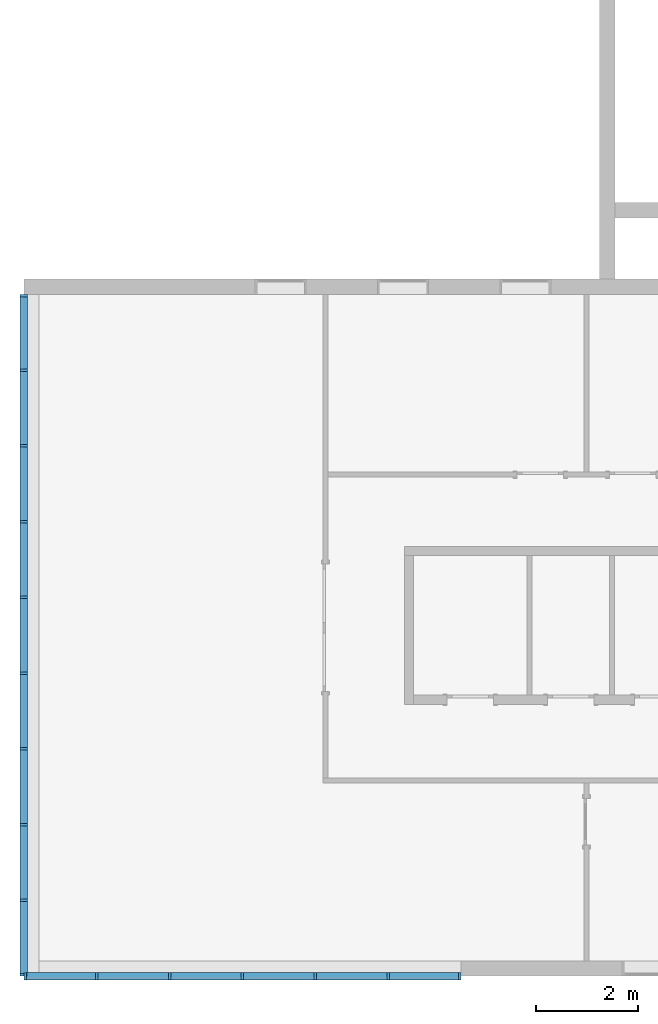
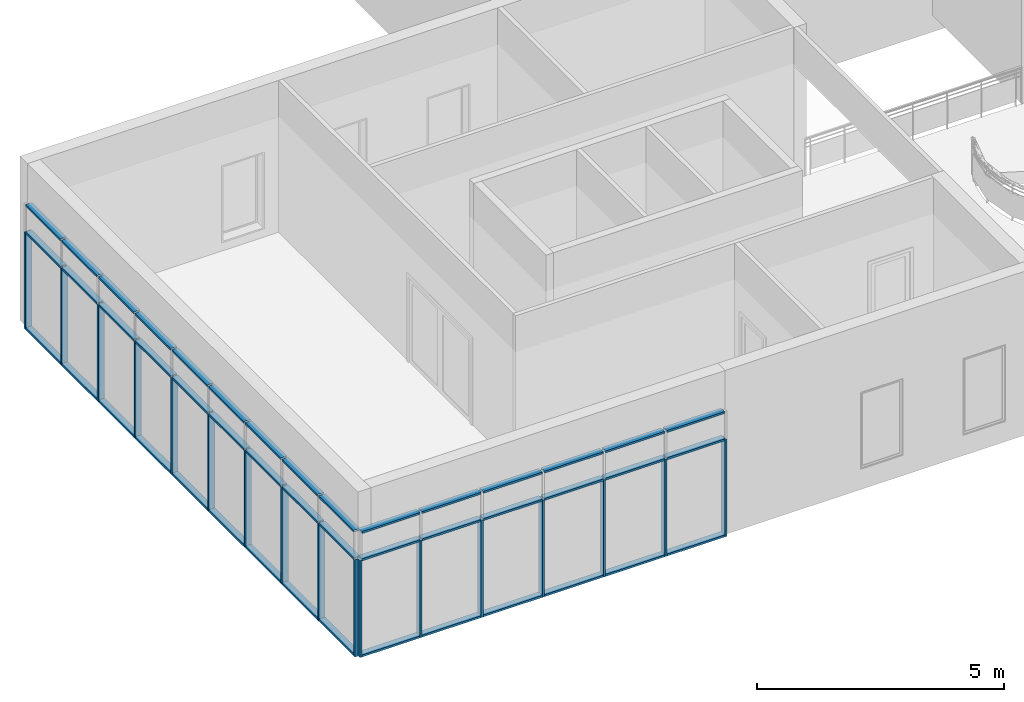
# One storey, part 1 of 13: 62 members, 2 elements without a shape of their own.
"""IFC2X3 building model written with IfcOpenShell, lengths in millimetres."""

from ifc_helpers import new_model, entity, si_unit, converted_unit, derived_unit, direction, frame, frame_2d, origin, origin_2d_with_axis, place, context, subcontext, project, spatial, rectangle, extrude, material, type_object, element, aggregate, save


model = new_model("IFC2X3")

# Units and contexts
model_context = context("Model", 3, precision=0.01, world=origin(), true_north=direction((6.12303176911189e-17, 1.0)))
context_of_model = context(None, 3, precision=0.01, world=origin(), true_north=direction((6.12303176911189e-17, 1.0)))
body_context = subcontext(model_context, "Body", "Model", "MODEL_VIEW")
ifc_project = project(units=[si_unit("LENGTHUNIT", "METRE", prefix="MILLI"), si_unit("AREAUNIT", "SQUARE_METRE"), si_unit("VOLUMEUNIT", "CUBIC_METRE"), converted_unit("PLANEANGLEUNIT", "DEGREE", entity("IfcRatioMeasure", 0.0174532925199433), si_unit("PLANEANGLEUNIT", "RADIAN"), dimensions=[0, 0, 0, 0, 0, 0, 0]), si_unit("MASSUNIT", "GRAM", prefix="KILO"), si_unit("TIMEUNIT", "SECOND"), si_unit("FREQUENCYUNIT", "HERTZ"), si_unit("THERMODYNAMICTEMPERATUREUNIT", "DEGREE_CELSIUS"), derived_unit("THERMALTRANSMITTANCEUNIT", [(si_unit("MASSUNIT", "GRAM", prefix="KILO"), 1), (si_unit("THERMODYNAMICTEMPERATUREUNIT", "KELVIN"), -1), (si_unit("TIMEUNIT", "SECOND"), -3)]), derived_unit("VOLUMETRICFLOWRATEUNIT", [(si_unit("LENGTHUNIT", "METRE"), 3), (si_unit("TIMEUNIT", "SECOND"), -1)]), si_unit("ELECTRICCURRENTUNIT", "AMPERE"), si_unit("ELECTRICVOLTAGEUNIT", "VOLT"), si_unit("POWERUNIT", "WATT"), si_unit("FORCEUNIT", "NEWTON", prefix="KILO"), si_unit("ILLUMINANCEUNIT", "LUX"), si_unit("LUMINOUSFLUXUNIT", "LUMEN"), si_unit("LUMINOUSINTENSITYUNIT", "CANDELA"), si_unit("PRESSUREUNIT", "PASCAL")], contexts=[model_context, context_of_model])

# Site, building, storey
site_placement = place(None, origin())
site = spatial("IfcSite", under=ifc_project, at=site_placement, CompositionType="ELEMENT")
building_placement = place(site_placement, origin())
building = spatial("IfcBuilding", under=site, at=building_placement, CompositionType="ELEMENT")
storey_placement = place(building_placement, frame((0.0, 0.0, 3750.0)))
storey = spatial("IfcBuildingStorey", under=building, at=storey_placement, Name="02. 2 etg.", CompositionType="ELEMENT", Elevation=3750.00000000068)

# Curtain wall, members
curtain_wall_type = type_object("IfcCurtainWallType", Name="Curtain Wall:Storefront", PredefinedType="NOTDEFINED")
curtain_wall_1_placement = place(storey_placement, frame((0.0, 0.0, -3750.0)))
curtain_wall_1 = element("IfcCurtainWall", 1, at=curtain_wall_1_placement, inside=storey, type_object=curtain_wall_type, Name="Curtain Wall:Storefront", ObjectType="Curtain Wall:Storefront")
ifc_material = material(Name="Aluminium")
member_1_placement = place(curtain_wall_1_placement, frame((-315.0, -13390.0, 6500.0)))
member_1 = element("IfcMember", 2, at=member_1_placement, material=ifc_material, Name="Curtain Wall:Storefront:8486", ObjectType="Curtain Wall:Storefront:8486", context=body_context, shape_type="SweptSolid", body=[
    extrude(rectangle(XDim=1411.66666666667, YDim=150.0, at=frame_2d((1.08002495835535e-12, 0.0), x_axis=(1.0, 0.0))), frame((75.0, 705.833333333337, 0.0), z_axis=(0.0, 0.0, 1.0), x_axis=(0.0, 1.0, 0.0)), (0.0, 0.0, 1.0), 49.9999999999995),
])
member_2_placement = place(curtain_wall_1_placement, frame((-315.0, -1521.66666666661, 3450.0)))
member_2 = element("IfcMember", 3, at=member_2_placement, material=ifc_material, Name="Curtain Wall:Storefront:8486", ObjectType="Curtain Wall:Storefront:8486", context=body_context, shape_type="SweptSolid", body=[
    extrude(rectangle(XDim=1411.66666666667, YDim=150.0, at=origin_2d_with_axis()), frame((75.0, 705.833333333337, 0.0), z_axis=(0.0, 0.0, 1.0), x_axis=(0.0, -1.0, 0.0)), (0.0, 0.0, 1.0), 50.0),
])
member_3_placement = place(curtain_wall_1_placement, frame((-315.0, -13440.0, 3450.0)))
member_3 = element("IfcMember", 4, at=member_3_placement, material=ifc_material, Name="Curtain Wall:Storefront:8486", ObjectType="Curtain Wall:Storefront:8486", context=body_context, shape_type="SweptSolid", body=[
    extrude(rectangle(XDim=150.0, YDim=49.9999999999995, at=frame_2d((2.1316282072803e-14, -1.08357767203415e-12), x_axis=(1.0, 0.0))), frame((75.0, 25.0, 0.0)), (0.0, 0.0, 1.0), 2400.0),
])
member_4_placement = place(curtain_wall_1_placement, frame((-315.0, -1521.66666666661, 6500.0)))
member_4 = element("IfcMember", 5, at=member_4_placement, material=ifc_material, Name="Curtain Wall:Storefront:8486", ObjectType="Curtain Wall:Storefront:8486", context=body_context, shape_type="SweptSolid", body=[
    extrude(rectangle(XDim=1411.66666666667, YDim=150.0, at=origin_2d_with_axis()), frame((75.0, 705.833333333337, 0.0), z_axis=(0.0, 0.0, 1.0), x_axis=(0.0, 1.0, 0.0)), (0.0, 0.0, 1.0), 49.9999999999995),
])
member_5_placement = place(curtain_wall_1_placement, frame((-315.0, -3008.33333333329, 6500.0)))
member_5 = element("IfcMember", 6, at=member_5_placement, material=ifc_material, Name="Curtain Wall:Storefront:8486", ObjectType="Curtain Wall:Storefront:8486", context=body_context, shape_type="SweptSolid", body=[
    extrude(rectangle(XDim=1436.66666666667, YDim=150.0, at=frame_2d((0.0, 3.5527136788005e-14), x_axis=(1.0, 0.0))), frame((75.0, 718.333333333337, 0.0), z_axis=(0.0, 0.0, 1.0), x_axis=(0.0, 1.0, 0.0)), (0.0, 0.0, 1.0), 49.9999999999995),
])
member_6_placement = place(curtain_wall_1_placement, frame((-315.0, -4495.0, 6500.0)))
member_6 = element("IfcMember", 7, at=member_6_placement, material=ifc_material, Name="Curtain Wall:Storefront:8486", ObjectType="Curtain Wall:Storefront:8486", context=body_context, shape_type="SweptSolid", body=[
    extrude(rectangle(XDim=1436.66666666667, YDim=150.0, at=frame_2d((2.8421709430404e-13, 0.0), x_axis=(1.0, 0.0))), frame((75.0, 718.333333333336, 0.0), z_axis=(0.0, 0.0, 1.0), x_axis=(0.0, 1.0, 0.0)), (0.0, 0.0, 1.0), 49.9999999999995),
])
member_7_placement = place(curtain_wall_1_placement, frame((-315.0, -5981.66666666663, 6500.0)))
member_7 = element("IfcMember", 8, at=member_7_placement, material=ifc_material, Name="Curtain Wall:Storefront:8486", ObjectType="Curtain Wall:Storefront:8486", context=body_context, shape_type="SweptSolid", body=[
    extrude(rectangle(XDim=1436.66666666667, YDim=150.0, at=frame_2d((8.5265128291212e-13, 0.0), x_axis=(1.0, 0.0))), frame((75.0, 718.333333333336, 0.0), z_axis=(0.0, 0.0, 1.0), x_axis=(0.0, 1.0, 0.0)), (0.0, 0.0, 1.0), 49.9999999999995),
])
member_8_placement = place(curtain_wall_1_placement, frame((-315.0, -7468.33333333331, 6500.0)))
member_8 = element("IfcMember", 9, at=member_8_placement, material=ifc_material, Name="Curtain Wall:Storefront:8486", ObjectType="Curtain Wall:Storefront:8486", context=body_context, shape_type="SweptSolid", body=[
    extrude(rectangle(XDim=1436.66666666667, YDim=150.0, at=frame_2d((5.6843418860808e-13, 0.0), x_axis=(1.0, 0.0))), frame((75.0, 718.333333333337, 0.0), z_axis=(0.0, 0.0, 1.0), x_axis=(0.0, 1.0, 0.0)), (0.0, 0.0, 1.0), 49.9999999999995),
])
member_9_placement = place(curtain_wall_1_placement, frame((-315.0, -8955.0, 6500.0)))
member_9 = element("IfcMember", 10, at=member_9_placement, material=ifc_material, Name="Curtain Wall:Storefront:8486", ObjectType="Curtain Wall:Storefront:8486", context=body_context, shape_type="SweptSolid", body=[
    extrude(rectangle(XDim=1436.66666666667, YDim=150.0, at=frame_2d((-5.6843418860808e-13, -3.5527136788005e-14), x_axis=(1.0, 0.0))), frame((75.0, 718.333333333338, 0.0), z_axis=(0.0, 0.0, 1.0), x_axis=(0.0, 1.0, 0.0)), (0.0, 0.0, 1.0), 49.9999999999995),
])
member_10_placement = place(curtain_wall_1_placement, frame((-315.0, -10441.6666666667, 6500.0)))
member_10 = element("IfcMember", 11, at=member_10_placement, material=ifc_material, Name="Curtain Wall:Storefront:8486", ObjectType="Curtain Wall:Storefront:8486", context=body_context, shape_type="SweptSolid", body=[
    extrude(rectangle(XDim=1436.66666666667, YDim=150.0, at=origin_2d_with_axis()), frame((75.0, 718.333333333337, 0.0), z_axis=(0.0, 0.0, 1.0), x_axis=(0.0, 1.0, 0.0)), (0.0, 0.0, 1.0), 49.9999999999995),
])
member_11_placement = place(curtain_wall_1_placement, frame((-315.0, -11928.3333333333, 6500.0)))
member_11 = element("IfcMember", 12, at=member_11_placement, material=ifc_material, Name="Curtain Wall:Storefront:8486", ObjectType="Curtain Wall:Storefront:8486", context=body_context, shape_type="SweptSolid", body=[
    extrude(rectangle(XDim=1436.66666666667, YDim=150.0, at=origin_2d_with_axis()), frame((75.0, 718.333333333337, 0.0), z_axis=(0.0, 0.0, 1.0), x_axis=(0.0, 1.0, 0.0)), (0.0, 0.0, 1.0), 49.9999999999995),
])
member_12_placement = place(curtain_wall_1_placement, frame((-315.0, -3008.33333333329, 3450.0)))
member_12 = element("IfcMember", 13, at=member_12_placement, material=ifc_material, Name="Curtain Wall:Storefront:8486", ObjectType="Curtain Wall:Storefront:8486", context=body_context, shape_type="SweptSolid", body=[
    extrude(rectangle(XDim=1436.66666666667, YDim=150.0, at=frame_2d((-1.70530256582424e-13, -1.4210854715202e-14), x_axis=(1.0, 0.0))), frame((75.0, 718.333333333337, 0.0), z_axis=(0.0, 0.0, 1.0), x_axis=(0.0, -1.0, 0.0)), (0.0, 0.0, 1.0), 50.0),
])
member_13_placement = place(curtain_wall_1_placement, frame((-315.0, -4495.0, 3450.0)))
member_13 = element("IfcMember", 14, at=member_13_placement, material=ifc_material, Name="Curtain Wall:Storefront:8486", ObjectType="Curtain Wall:Storefront:8486", context=body_context, shape_type="SweptSolid", body=[
    extrude(rectangle(XDim=1436.66666666667, YDim=150.0, at=frame_2d((-2.8421709430404e-13, 1.4210854715202e-14), x_axis=(1.0, 0.0))), frame((75.0, 718.333333333337, 0.0), z_axis=(0.0, 0.0, 1.0), x_axis=(0.0, -1.0, 0.0)), (0.0, 0.0, 1.0), 50.0),
])
member_14_placement = place(curtain_wall_1_placement, frame((-315.0, -5981.66666666663, 3450.0)))
member_14 = element("IfcMember", 15, at=member_14_placement, material=ifc_material, Name="Curtain Wall:Storefront:8486", ObjectType="Curtain Wall:Storefront:8486", context=body_context, shape_type="SweptSolid", body=[
    extrude(rectangle(XDim=1436.66666666667, YDim=150.0, at=frame_2d((5.6843418860808e-13, -1.4210854715202e-14), x_axis=(1.0, 0.0))), frame((75.0, 718.333333333337, 0.0), z_axis=(0.0, 0.0, 1.0), x_axis=(0.0, -1.0, 0.0)), (0.0, 0.0, 1.0), 50.0),
])
member_15_placement = place(curtain_wall_1_placement, frame((-315.0, -7468.33333333331, 3450.0)))
member_15 = element("IfcMember", 16, at=member_15_placement, material=ifc_material, Name="Curtain Wall:Storefront:8486", ObjectType="Curtain Wall:Storefront:8486", context=body_context, shape_type="SweptSolid", body=[
    extrude(rectangle(XDim=1436.66666666667, YDim=150.0, at=frame_2d((-5.6843418860808e-13, -1.4210854715202e-14), x_axis=(1.0, 0.0))), frame((75.0, 718.333333333336, 0.0), z_axis=(0.0, 0.0, 1.0), x_axis=(0.0, -1.0, 0.0)), (0.0, 0.0, 1.0), 50.0),
])
member_16_placement = place(curtain_wall_1_placement, frame((-315.0, -8955.0, 3450.0)))
member_16 = element("IfcMember", 17, at=member_16_placement, material=ifc_material, Name="Curtain Wall:Storefront:8486", ObjectType="Curtain Wall:Storefront:8486", context=body_context, shape_type="SweptSolid", body=[
    extrude(rectangle(XDim=1436.66666666667, YDim=150.0, at=frame_2d((5.6843418860808e-13, -1.4210854715202e-14), x_axis=(1.0, 0.0))), frame((75.0, 718.333333333337, 0.0), z_axis=(0.0, 0.0, 1.0), x_axis=(0.0, -1.0, 0.0)), (0.0, 0.0, 1.0), 50.0),
])
member_17_placement = place(curtain_wall_1_placement, frame((-315.0, -10441.6666666667, 3450.0)))
member_17 = element("IfcMember", 18, at=member_17_placement, material=ifc_material, Name="Curtain Wall:Storefront:8486", ObjectType="Curtain Wall:Storefront:8486", context=body_context, shape_type="SweptSolid", body=[
    extrude(rectangle(XDim=1436.66666666667, YDim=150.0, at=frame_2d((5.6843418860808e-13, 1.4210854715202e-14), x_axis=(1.0, 0.0))), frame((75.0, 718.333333333337, 0.0), z_axis=(0.0, 0.0, 1.0), x_axis=(0.0, -1.0, 0.0)), (0.0, 0.0, 1.0), 50.0),
])
member_18_placement = place(curtain_wall_1_placement, frame((-315.0, -11928.3333333333, 3450.0)))
member_18 = element("IfcMember", 19, at=member_18_placement, material=ifc_material, Name="Curtain Wall:Storefront:8486", ObjectType="Curtain Wall:Storefront:8486", context=body_context, shape_type="SweptSolid", body=[
    extrude(rectangle(XDim=1436.66666666667, YDim=150.0, at=frame_2d((0.0, -1.4210854715202e-14), x_axis=(1.0, 0.0))), frame((75.0, 718.333333333337, 0.0), z_axis=(0.0, 0.0, 1.0), x_axis=(0.0, -1.0, 0.0)), (0.0, 0.0, 1.0), 50.0),
])
member_19_placement = place(curtain_wall_1_placement, frame((-315.0, -13390.0, 3450.0)))
member_19 = element("IfcMember", 20, at=member_19_placement, material=ifc_material, Name="Curtain Wall:Storefront:8486", ObjectType="Curtain Wall:Storefront:8486", context=body_context, shape_type="SweptSolid", body=[
    extrude(rectangle(XDim=1411.66666666667, YDim=150.0, at=frame_2d((-1.08002495835535e-12, 1.4210854715202e-14), x_axis=(1.0, 0.0))), frame((75.0, 705.833333333337, 0.0), z_axis=(0.0, 0.0, 1.0), x_axis=(0.0, -1.0, 0.0)), (0.0, 0.0, 1.0), 50.0),
])
member_20_placement = place(curtain_wall_1_placement, frame((-315.0, -110.0, 3450.0)))
member_20 = element("IfcMember", 21, at=member_20_placement, material=ifc_material, Name="Curtain Wall:Storefront:8486", ObjectType="Curtain Wall:Storefront:8486", context=body_context, shape_type="SweptSolid", body=[
    extrude(rectangle(XDim=50.0, YDim=150.0, at=frame_2d((1.24344978758018e-14, 1.4210854715202e-14), x_axis=(1.0, 0.0))), frame((75.0, 25.0, 0.0), z_axis=(0.0, 0.0, 1.0), x_axis=(0.0, -1.0, 0.0)), (0.0, 0.0, 1.0), 2400.0),
])
member_21_placement = place(curtain_wall_1_placement, frame((-315.0, -1521.66666666661, 5825.0)))
member_21 = element("IfcMember", 22, at=member_21_placement, material=ifc_material, Name="Curtain Wall:Storefront:8486", ObjectType="Curtain Wall:Storefront:8486", context=body_context, shape_type="SweptSolid", body=[
    extrude(rectangle(XDim=1411.66666666667, YDim=150.0, at=frame_2d((0.0, -2.8421709430404e-14), x_axis=(1.0, 0.0))), frame((75.0, 705.833333333337, 0.0), z_axis=(0.0, 0.0, 1.0), x_axis=(0.0, 1.0, 0.0)), (0.0, 0.0, 1.0), 49.9999999999995),
])
member_22_placement = place(curtain_wall_1_placement, frame((-315.0, -3008.33333333329, 5825.0)))
member_22 = element("IfcMember", 23, at=member_22_placement, material=ifc_material, Name="Curtain Wall:Storefront:8486", ObjectType="Curtain Wall:Storefront:8486", context=body_context, shape_type="SweptSolid", body=[
    extrude(rectangle(XDim=1436.66666666667, YDim=150.0, at=frame_2d((0.0, 3.5527136788005e-14), x_axis=(1.0, 0.0))), frame((75.0, 718.333333333337, 0.0), z_axis=(0.0, 0.0, 1.0), x_axis=(0.0, 1.0, 0.0)), (0.0, 0.0, 1.0), 49.9999999999995),
])
member_23_placement = place(curtain_wall_1_placement, frame((-315.0, -4495.0, 5825.0)))
member_23 = element("IfcMember", 24, at=member_23_placement, material=ifc_material, Name="Curtain Wall:Storefront:8486", ObjectType="Curtain Wall:Storefront:8486", context=body_context, shape_type="SweptSolid", body=[
    extrude(rectangle(XDim=1436.66666666667, YDim=150.0, at=frame_2d((-2.8421709430404e-13, 0.0), x_axis=(1.0, 0.0))), frame((75.0, 718.333333333337, 0.0), z_axis=(0.0, 0.0, 1.0), x_axis=(0.0, 1.0, 0.0)), (0.0, 0.0, 1.0), 49.9999999999995),
])
member_24_placement = place(curtain_wall_1_placement, frame((-315.0, -5981.66666666663, 5825.0)))
member_24 = element("IfcMember", 25, at=member_24_placement, material=ifc_material, Name="Curtain Wall:Storefront:8486", ObjectType="Curtain Wall:Storefront:8486", context=body_context, shape_type="SweptSolid", body=[
    extrude(rectangle(XDim=1436.66666666667, YDim=150.0, at=frame_2d((-2.8421709430404e-13, 3.5527136788005e-14), x_axis=(1.0, 0.0))), frame((75.0, 718.333333333337, 0.0), z_axis=(0.0, 0.0, 1.0), x_axis=(0.0, 1.0, 0.0)), (0.0, 0.0, 1.0), 49.9999999999995),
])
member_25_placement = place(curtain_wall_1_placement, frame((-315.0, -7468.33333333331, 5825.0)))
member_25 = element("IfcMember", 26, at=member_25_placement, material=ifc_material, Name="Curtain Wall:Storefront:8486", ObjectType="Curtain Wall:Storefront:8486", context=body_context, shape_type="SweptSolid", body=[
    extrude(rectangle(XDim=1436.66666666667, YDim=150.0, at=frame_2d((5.6843418860808e-13, 0.0), x_axis=(1.0, 0.0))), frame((75.0, 718.333333333336, 0.0), z_axis=(0.0, 0.0, 1.0), x_axis=(0.0, 1.0, 0.0)), (0.0, 0.0, 1.0), 49.9999999999995),
])
member_26_placement = place(curtain_wall_1_placement, frame((-315.0, -8955.0, 5825.0)))
member_26 = element("IfcMember", 27, at=member_26_placement, material=ifc_material, Name="Curtain Wall:Storefront:8486", ObjectType="Curtain Wall:Storefront:8486", context=body_context, shape_type="SweptSolid", body=[
    extrude(rectangle(XDim=1436.66666666667, YDim=150.0, at=frame_2d((-5.6843418860808e-13, 0.0), x_axis=(1.0, 0.0))), frame((75.0, 718.333333333337, 0.0), z_axis=(0.0, 0.0, 1.0), x_axis=(0.0, 1.0, 0.0)), (0.0, 0.0, 1.0), 49.9999999999995),
])
member_27_placement = place(curtain_wall_1_placement, frame((-315.0, -10441.6666666667, 5825.0)))
member_27 = element("IfcMember", 28, at=member_27_placement, material=ifc_material, Name="Curtain Wall:Storefront:8486", ObjectType="Curtain Wall:Storefront:8486", context=body_context, shape_type="SweptSolid", body=[
    extrude(rectangle(XDim=1436.66666666667, YDim=150.0, at=origin_2d_with_axis()), frame((75.0, 718.333333333337, 0.0), z_axis=(0.0, 0.0, 1.0), x_axis=(0.0, 1.0, 0.0)), (0.0, 0.0, 1.0), 49.9999999999995),
])
member_28_placement = place(curtain_wall_1_placement, frame((-315.0, -11928.3333333333, 5825.0)))
member_28 = element("IfcMember", 29, at=member_28_placement, material=ifc_material, Name="Curtain Wall:Storefront:8486", ObjectType="Curtain Wall:Storefront:8486", context=body_context, shape_type="SweptSolid", body=[
    extrude(rectangle(XDim=1436.66666666667, YDim=150.0, at=origin_2d_with_axis()), frame((75.0, 718.333333333337, 0.0), z_axis=(0.0, 0.0, 1.0), x_axis=(0.0, 1.0, 0.0)), (0.0, 0.0, 1.0), 49.9999999999995),
])
member_29_placement = place(curtain_wall_1_placement, frame((-315.0, -13390.0, 5825.0)))
member_29 = element("IfcMember", 30, at=member_29_placement, material=ifc_material, Name="Curtain Wall:Storefront:8486", ObjectType="Curtain Wall:Storefront:8486", context=body_context, shape_type="SweptSolid", body=[
    extrude(rectangle(XDim=1411.66666666667, YDim=150.0, at=frame_2d((1.08002495835535e-12, 0.0), x_axis=(1.0, 0.0))), frame((75.0, 705.833333333337, 0.0), z_axis=(0.0, 0.0, 1.0), x_axis=(0.0, 1.0, 0.0)), (0.0, 0.0, 1.0), 49.9999999999995),
])
member_30_placement = place(curtain_wall_1_placement, frame((-315.0, -1571.66666666661, 3450.0)))
member_30 = element("IfcMember", 31, at=member_30_placement, material=ifc_material, Name="Curtain Wall:Storefront:8486", ObjectType="Curtain Wall:Storefront:8486", context=body_context, shape_type="SweptSolid", body=[
    extrude(rectangle(XDim=150.0, YDim=50.0, at=frame_2d((3.5527136788005e-14, -1.36779476633819e-13), x_axis=(1.0, 0.0))), frame((75.0, 25.0, 0.0)), (0.0, 0.0, 1.0), 2400.0),
])
member_31_placement = place(curtain_wall_1_placement, frame((-315.0, -3058.33333333329, 3450.0)))
member_31 = element("IfcMember", 32, at=member_31_placement, material=ifc_material, Name="Curtain Wall:Storefront:8486", ObjectType="Curtain Wall:Storefront:8486", context=body_context, shape_type="SweptSolid", body=[
    extrude(rectangle(XDim=150.0, YDim=50.0, at=frame_2d((2.1316282072803e-14, -2.71782596428238e-13), x_axis=(1.0, 0.0))), frame((75.0, 25.0, 0.0)), (0.0, 0.0, 1.0), 2400.0),
])
member_32_placement = place(curtain_wall_1_placement, frame((-315.0, -4545.0, 3450.0)))
member_32 = element("IfcMember", 33, at=member_32_placement, material=ifc_material, Name="Curtain Wall:Storefront:8486", ObjectType="Curtain Wall:Storefront:8486", context=body_context, shape_type="SweptSolid", body=[
    extrude(rectangle(XDim=150.0, YDim=50.0, at=frame_2d((-3.5527136788005e-14, 2.71782596428238e-13), x_axis=(1.0, 0.0))), frame((75.0, 25.0, 0.0)), (0.0, 0.0, 1.0), 2400.0),
])
member_33_placement = place(curtain_wall_1_placement, frame((-315.0, -6031.66666666663, 3450.0)))
member_33 = element("IfcMember", 34, at=member_33_placement, material=ifc_material, Name="Curtain Wall:Storefront:8486", ObjectType="Curtain Wall:Storefront:8486", context=body_context, shape_type="SweptSolid", body=[
    extrude(rectangle(XDim=150.0, YDim=50.0000000000005, at=frame_2d((2.1316282072803e-14, 0.0), x_axis=(1.0, 0.0))), frame((75.0, 25.0, 0.0)), (0.0, 0.0, 1.0), 2400.0),
])
member_34_placement = place(curtain_wall_1_placement, frame((-315.0, -7518.33333333331, 3450.0)))
member_34 = element("IfcMember", 35, at=member_34_placement, material=ifc_material, Name="Curtain Wall:Storefront:8486", ObjectType="Curtain Wall:Storefront:8486", context=body_context, shape_type="SweptSolid", body=[
    extrude(rectangle(XDim=150.0, YDim=50.0000000000005, at=frame_2d((3.5527136788005e-14, 0.0), x_axis=(1.0, 0.0))), frame((75.0, 25.0, 0.0)), (0.0, 0.0, 1.0), 2400.0),
])
member_35_placement = place(curtain_wall_1_placement, frame((-315.0, -9005.0, 3450.0)))
member_35 = element("IfcMember", 36, at=member_35_placement, material=ifc_material, Name="Curtain Wall:Storefront:8486", ObjectType="Curtain Wall:Storefront:8486", context=body_context, shape_type="SweptSolid", body=[
    extrude(rectangle(XDim=150.0, YDim=50.0000000000005, at=frame_2d((2.1316282072803e-14, 0.0), x_axis=(1.0, 0.0))), frame((75.0, 25.0, 0.0)), (0.0, 0.0, 1.0), 2400.0),
])
member_36_placement = place(curtain_wall_1_placement, frame((-315.0, -10491.6666666667, 3450.0)))
member_36 = element("IfcMember", 37, at=member_36_placement, material=ifc_material, Name="Curtain Wall:Storefront:8486", ObjectType="Curtain Wall:Storefront:8486", context=body_context, shape_type="SweptSolid", body=[
    extrude(rectangle(XDim=150.0, YDim=49.9999999999995, at=frame_2d((0.0, -1.08357767203415e-12), x_axis=(1.0, 0.0))), frame((75.0, 25.0, 0.0)), (0.0, 0.0, 1.0), 2400.0),
])
member_37_placement = place(curtain_wall_1_placement, frame((-315.0, -11978.3333333333, 3450.0)))
member_37 = element("IfcMember", 38, at=member_37_placement, material=ifc_material, Name="Curtain Wall:Storefront:8486", ObjectType="Curtain Wall:Storefront:8486", context=body_context, shape_type="SweptSolid", body=[
    extrude(rectangle(XDim=150.0, YDim=49.9999999999995, at=frame_2d((1.4210854715202e-14, 1.08357767203415e-12), x_axis=(1.0, 0.0))), frame((75.0, 25.0, 0.0)), (0.0, 0.0, 1.0), 2400.0),
])
aggregate(curtain_wall_1, [member_1, member_2, member_3, member_4, member_5, member_6, member_7, member_8, member_9, member_10, member_11, member_12, member_13, member_14, member_15, member_16, member_17, member_18, member_19, member_20, member_21, member_22, member_23, member_24, member_25, member_26, member_27, member_28, member_29, member_30, member_31, member_32, member_33, member_34, member_35, member_36, member_37])

curtain_wall_2_placement = place(storey_placement, frame((0.0, 0.0, -3750.0)))
curtain_wall_2 = element("IfcCurtainWall", 39, at=curtain_wall_2_placement, inside=storey, type_object=curtain_wall_type, Name="Curtain Wall:Storefront", ObjectType="Curtain Wall:Storefront")
member_38_placement = place(curtain_wall_2_placement, frame((6935.0, -13515.0, 6500.0)))
member_38 = element("IfcMember", 40, at=member_38_placement, material=ifc_material, Name="Curtain Wall:Storefront:8486", ObjectType="Curtain Wall:Storefront:8486", context=body_context, shape_type="SweptSolid", body=[
    extrude(rectangle(XDim=1355.0, YDim=150.000000000001, at=origin_2d_with_axis()), frame((677.500000000002, 75.0, 0.0), z_axis=(0.0, 0.0, 1.0), x_axis=(-1.0, 0.0, 0.0)), (0.0, 0.0, 1.0), 49.9999999999995),
])
member_39_placement = place(curtain_wall_2_placement, frame((-190.0, -13515.0, 3450.0)))
member_39 = element("IfcMember", 41, at=member_39_placement, material=ifc_material, Name="Curtain Wall:Storefront:8486", ObjectType="Curtain Wall:Storefront:8486", context=body_context, shape_type="SweptSolid", body=[
    extrude(rectangle(XDim=1355.0, YDim=150.000000000001, at=frame_2d((0.0, -2.16715534406831e-12), x_axis=(1.0, 0.0))), frame((677.500000000002, 75.0, 0.0)), (0.0, 0.0, 1.0), 50.0),
])
member_40_placement = place(curtain_wall_2_placement, frame((8290.0, -13515.0, 3450.0)))
member_40 = element("IfcMember", 42, at=member_40_placement, material=ifc_material, Name="Curtain Wall:Storefront:8486", ObjectType="Curtain Wall:Storefront:8486", context=body_context, shape_type="SweptSolid", body=[
    extrude(rectangle(XDim=150.000000000001, YDim=50.0000000000005, at=frame_2d((0.0, 5.41788836017076e-13), x_axis=(1.0, 0.0))), frame((25.0, 75.0, 0.0), z_axis=(0.0, 0.0, 1.0), x_axis=(0.0, 1.0, 0.0)), (0.0, 0.0, 1.0), 2400.0),
])
member_41_placement = place(curtain_wall_2_placement, frame((-190.0, -13515.0, 6500.0)))
member_41 = element("IfcMember", 43, at=member_41_placement, material=ifc_material, Name="Curtain Wall:Storefront:8486", ObjectType="Curtain Wall:Storefront:8486", context=body_context, shape_type="SweptSolid", body=[
    extrude(rectangle(XDim=1355.0, YDim=150.000000000001, at=origin_2d_with_axis()), frame((677.500000000003, 75.0, 0.0), z_axis=(0.0, 0.0, 1.0), x_axis=(-1.0, 0.0, 0.0)), (0.0, 0.0, 1.0), 49.9999999999995),
])
member_42_placement = place(curtain_wall_2_placement, frame((1215.0, -13515.0, 6500.0)))
member_42 = element("IfcMember", 44, at=member_42_placement, material=ifc_material, Name="Curtain Wall:Storefront:8486", ObjectType="Curtain Wall:Storefront:8486", context=body_context, shape_type="SweptSolid", body=[
    extrude(rectangle(XDim=1380.0, YDim=150.000000000001, at=frame_2d((0.0, -2.16715534406831e-12), x_axis=(1.0, 0.0))), frame((690.0, 75.0, 0.0), z_axis=(0.0, 0.0, 1.0), x_axis=(-1.0, 0.0, 0.0)), (0.0, 0.0, 1.0), 49.9999999999995),
])
member_43_placement = place(curtain_wall_2_placement, frame((2645.0, -13515.0, 6500.0)))
member_43 = element("IfcMember", 45, at=member_43_placement, material=ifc_material, Name="Curtain Wall:Storefront:8486", ObjectType="Curtain Wall:Storefront:8486", context=body_context, shape_type="SweptSolid", body=[
    extrude(rectangle(XDim=1380.0, YDim=150.000000000001, at=frame_2d((2.8421709430404e-13, 0.0), x_axis=(1.0, 0.0))), frame((690.0, 75.0, 0.0), z_axis=(0.0, 0.0, 1.0), x_axis=(-1.0, 0.0, 0.0)), (0.0, 0.0, 1.0), 49.9999999999995),
])
member_44_placement = place(curtain_wall_2_placement, frame((4075.0, -13515.0, 6500.0)))
member_44 = element("IfcMember", 46, at=member_44_placement, material=ifc_material, Name="Curtain Wall:Storefront:8486", ObjectType="Curtain Wall:Storefront:8486", context=body_context, shape_type="SweptSolid", body=[
    extrude(rectangle(XDim=1380.0, YDim=150.000000000001, at=frame_2d((-5.6843418860808e-13, -1.08713038571295e-12), x_axis=(1.0, 0.0))), frame((690.0, 75.0, 0.0), z_axis=(0.0, 0.0, 1.0), x_axis=(-1.0, 0.0, 0.0)), (0.0, 0.0, 1.0), 49.9999999999995),
])
member_45_placement = place(curtain_wall_2_placement, frame((5505.0, -13515.0, 6500.0)))
member_45 = element("IfcMember", 47, at=member_45_placement, material=ifc_material, Name="Curtain Wall:Storefront:8486", ObjectType="Curtain Wall:Storefront:8486", context=body_context, shape_type="SweptSolid", body=[
    extrude(rectangle(XDim=1380.0, YDim=150.000000000001, at=frame_2d((5.6843418860808e-13, 0.0), x_axis=(1.0, 0.0))), frame((690.0, 75.0, 0.0), z_axis=(0.0, 0.0, 1.0), x_axis=(-1.0, 0.0, 0.0)), (0.0, 0.0, 1.0), 49.9999999999995),
])
member_46_placement = place(curtain_wall_2_placement, frame((1215.0, -13515.0, 3450.0)))
member_46 = element("IfcMember", 48, at=member_46_placement, material=ifc_material, Name="Curtain Wall:Storefront:8486", ObjectType="Curtain Wall:Storefront:8486", context=body_context, shape_type="SweptSolid", body=[
    extrude(rectangle(XDim=1380.0, YDim=150.000000000001, at=frame_2d((-1.13686837721616e-13, 0.0), x_axis=(1.0, 0.0))), frame((690.0, 75.0, 0.0)), (0.0, 0.0, 1.0), 50.0),
])
member_47_placement = place(curtain_wall_2_placement, frame((2645.0, -13515.0, 3450.0)))
member_47 = element("IfcMember", 49, at=member_47_placement, material=ifc_material, Name="Curtain Wall:Storefront:8486", ObjectType="Curtain Wall:Storefront:8486", context=body_context, shape_type="SweptSolid", body=[
    extrude(rectangle(XDim=1380.0, YDim=150.000000000001, at=frame_2d((0.0, 2.16715534406831e-12), x_axis=(1.0, 0.0))), frame((690.0, 75.0, 0.0)), (0.0, 0.0, 1.0), 50.0),
])
member_48_placement = place(curtain_wall_2_placement, frame((4075.0, -13515.0, 3450.0)))
member_48 = element("IfcMember", 50, at=member_48_placement, material=ifc_material, Name="Curtain Wall:Storefront:8486", ObjectType="Curtain Wall:Storefront:8486", context=body_context, shape_type="SweptSolid", body=[
    extrude(rectangle(XDim=1380.0, YDim=150.000000000001, at=frame_2d((5.6843418860808e-13, 1.08713038571295e-12), x_axis=(1.0, 0.0))), frame((690.0, 75.0, 0.0)), (0.0, 0.0, 1.0), 50.0),
])
member_49_placement = place(curtain_wall_2_placement, frame((5505.0, -13515.0, 3450.0)))
member_49 = element("IfcMember", 51, at=member_49_placement, material=ifc_material, Name="Curtain Wall:Storefront:8486", ObjectType="Curtain Wall:Storefront:8486", context=body_context, shape_type="SweptSolid", body=[
    extrude(rectangle(XDim=1380.0, YDim=150.000000000001, at=frame_2d((-5.6843418860808e-13, 0.0), x_axis=(1.0, 0.0))), frame((690.0, 75.0, 0.0)), (0.0, 0.0, 1.0), 50.0),
])
member_50_placement = place(curtain_wall_2_placement, frame((6935.0, -13515.0, 3450.0)))
member_50 = element("IfcMember", 52, at=member_50_placement, material=ifc_material, Name="Curtain Wall:Storefront:8486", ObjectType="Curtain Wall:Storefront:8486", context=body_context, shape_type="SweptSolid", body=[
    extrude(rectangle(XDim=1355.0, YDim=150.000000000001, at=origin_2d_with_axis()), frame((677.500000000002, 75.0, 0.0)), (0.0, 0.0, 1.0), 50.0),
])
member_51_placement = place(curtain_wall_2_placement, frame((-240.0, -13515.0, 3450.0)))
member_51 = element("IfcMember", 53, at=member_51_placement, material=ifc_material, Name="Curtain Wall:Storefront:8486", ObjectType="Curtain Wall:Storefront:8486", context=body_context, shape_type="SweptSolid", body=[
    extrude(rectangle(XDim=50.0, YDim=150.000000000001, at=frame_2d((3.37507799486048e-14, -1.08002495835535e-12), x_axis=(1.0, 0.0))), frame((25.0, 75.0, 0.0)), (0.0, 0.0, 1.0), 2400.0),
])
member_52_placement = place(curtain_wall_2_placement, frame((-190.0, -13515.0, 5825.0)))
member_52 = element("IfcMember", 54, at=member_52_placement, material=ifc_material, Name="Curtain Wall:Storefront:8486", ObjectType="Curtain Wall:Storefront:8486", context=body_context, shape_type="SweptSolid", body=[
    extrude(rectangle(XDim=1355.0, YDim=150.000000000001, at=origin_2d_with_axis()), frame((677.500000000002, 75.0, 0.0), z_axis=(0.0, 0.0, 1.0), x_axis=(-1.0, 0.0, 0.0)), (0.0, 0.0, 1.0), 49.9999999999995),
])
member_53_placement = place(curtain_wall_2_placement, frame((1215.0, -13515.0, 5825.0)))
member_53 = element("IfcMember", 55, at=member_53_placement, material=ifc_material, Name="Curtain Wall:Storefront:8486", ObjectType="Curtain Wall:Storefront:8486", context=body_context, shape_type="SweptSolid", body=[
    extrude(rectangle(XDim=1380.0, YDim=150.000000000001, at=frame_2d((0.0, -2.16715534406831e-12), x_axis=(1.0, 0.0))), frame((690.0, 75.0, 0.0), z_axis=(0.0, 0.0, 1.0), x_axis=(-1.0, 0.0, 0.0)), (0.0, 0.0, 1.0), 49.9999999999995),
])
member_54_placement = place(curtain_wall_2_placement, frame((2645.0, -13515.0, 5825.0)))
member_54 = element("IfcMember", 56, at=member_54_placement, material=ifc_material, Name="Curtain Wall:Storefront:8486", ObjectType="Curtain Wall:Storefront:8486", context=body_context, shape_type="SweptSolid", body=[
    extrude(rectangle(XDim=1380.0, YDim=150.000000000001, at=origin_2d_with_axis()), frame((690.0, 75.0, 0.0), z_axis=(0.0, 0.0, 1.0), x_axis=(-1.0, 0.0, 0.0)), (0.0, 0.0, 1.0), 49.9999999999995),
])
member_55_placement = place(curtain_wall_2_placement, frame((4075.0, -13515.0, 5825.0)))
member_55 = element("IfcMember", 57, at=member_55_placement, material=ifc_material, Name="Curtain Wall:Storefront:8486", ObjectType="Curtain Wall:Storefront:8486", context=body_context, shape_type="SweptSolid", body=[
    extrude(rectangle(XDim=1380.0, YDim=149.999999999998, at=origin_2d_with_axis()), frame((690.0, 75.0, 0.0), z_axis=(0.0, 0.0, 1.0), x_axis=(-1.0, 0.0, 0.0)), (0.0, 0.0, 1.0), 49.9999999999995),
])
member_56_placement = place(curtain_wall_2_placement, frame((5505.0, -13515.0, 5825.0)))
member_56 = element("IfcMember", 58, at=member_56_placement, material=ifc_material, Name="Curtain Wall:Storefront:8486", ObjectType="Curtain Wall:Storefront:8486", context=body_context, shape_type="SweptSolid", body=[
    extrude(rectangle(XDim=1380.0, YDim=149.999999999998, at=frame_2d((-5.6843418860808e-13, 1.08002495835535e-12), x_axis=(1.0, 0.0))), frame((690.0, 75.0, 0.0), z_axis=(0.0, 0.0, 1.0), x_axis=(-1.0, 0.0, 0.0)), (0.0, 0.0, 1.0), 49.9999999999995),
])
member_57_placement = place(curtain_wall_2_placement, frame((6935.0, -13515.0, 5825.0)))
member_57 = element("IfcMember", 59, at=member_57_placement, material=ifc_material, Name="Curtain Wall:Storefront:8486", ObjectType="Curtain Wall:Storefront:8486", context=body_context, shape_type="SweptSolid", body=[
    extrude(rectangle(XDim=1355.0, YDim=149.999999999998, at=frame_2d((0.0, -1.08002495835535e-12), x_axis=(1.0, 0.0))), frame((677.500000000002, 75.0, 0.0), z_axis=(0.0, 0.0, 1.0), x_axis=(-1.0, 0.0, 0.0)), (0.0, 0.0, 1.0), 49.9999999999995),
])
member_58_placement = place(curtain_wall_2_placement, frame((1165.0, -13515.0, 3450.0)))
member_58 = element("IfcMember", 60, at=member_58_placement, material=ifc_material, Name="Curtain Wall:Storefront:8486", ObjectType="Curtain Wall:Storefront:8486", context=body_context, shape_type="SweptSolid", body=[
    extrude(rectangle(XDim=149.999999999998, YDim=50.0, at=origin_2d_with_axis()), frame((25.0, 75.0, 0.0), z_axis=(0.0, 0.0, 1.0), x_axis=(0.0, 1.0, 0.0)), (0.0, 0.0, 1.0), 2400.0),
])
member_59_placement = place(curtain_wall_2_placement, frame((2595.0, -13515.0, 3450.0)))
member_59 = element("IfcMember", 61, at=member_59_placement, material=ifc_material, Name="Curtain Wall:Storefront:8486", ObjectType="Curtain Wall:Storefront:8486", context=body_context, shape_type="SweptSolid", body=[
    extrude(rectangle(XDim=149.999999999998, YDim=50.0, at=frame_2d((0.0, 5.41788836017076e-13), x_axis=(1.0, 0.0))), frame((25.0, 75.0, 0.0), z_axis=(0.0, 0.0, 1.0), x_axis=(0.0, 1.0, 0.0)), (0.0, 0.0, 1.0), 2400.0),
])
member_60_placement = place(curtain_wall_2_placement, frame((4025.0, -13515.0, 3450.0)))
member_60 = element("IfcMember", 62, at=member_60_placement, material=ifc_material, Name="Curtain Wall:Storefront:8486", ObjectType="Curtain Wall:Storefront:8486", context=body_context, shape_type="SweptSolid", body=[
    extrude(rectangle(XDim=149.999999999998, YDim=50.0, at=frame_2d((0.0, -5.41788836017076e-13), x_axis=(1.0, 0.0))), frame((25.0, 75.0, 0.0), z_axis=(0.0, 0.0, 1.0), x_axis=(0.0, 1.0, 0.0)), (0.0, 0.0, 1.0), 2400.0),
])
member_61_placement = place(curtain_wall_2_placement, frame((5455.0, -13515.0, 3450.0)))
member_61 = element("IfcMember", 63, at=member_61_placement, material=ifc_material, Name="Curtain Wall:Storefront:8486", ObjectType="Curtain Wall:Storefront:8486", context=body_context, shape_type="SweptSolid", body=[
    extrude(rectangle(XDim=149.999999999998, YDim=50.0000000000005, at=frame_2d((2.16715534406831e-12, 0.0), x_axis=(1.0, 0.0))), frame((25.0, 75.0, 0.0), z_axis=(0.0, 0.0, 1.0), x_axis=(0.0, 1.0, 0.0)), (0.0, 0.0, 1.0), 2400.0),
])
member_62_placement = place(curtain_wall_2_placement, frame((6885.0, -13515.0, 3450.0)))
member_62 = element("IfcMember", 64, at=member_62_placement, material=ifc_material, Name="Curtain Wall:Storefront:8486", ObjectType="Curtain Wall:Storefront:8486", context=body_context, shape_type="SweptSolid", body=[
    extrude(rectangle(XDim=149.999999999998, YDim=50.0000000000005, at=origin_2d_with_axis()), frame((25.0, 75.0, 0.0), z_axis=(0.0, 0.0, 1.0), x_axis=(0.0, 1.0, 0.0)), (0.0, 0.0, 1.0), 2400.0),
])
aggregate(curtain_wall_2, [member_38, member_39, member_40, member_41, member_42, member_43, member_44, member_45, member_46, member_47, member_48, member_49, member_50, member_51, member_52, member_53, member_54, member_55, member_56, member_57, member_58, member_59, member_60, member_61, member_62])

save(model, "model.ifc")
